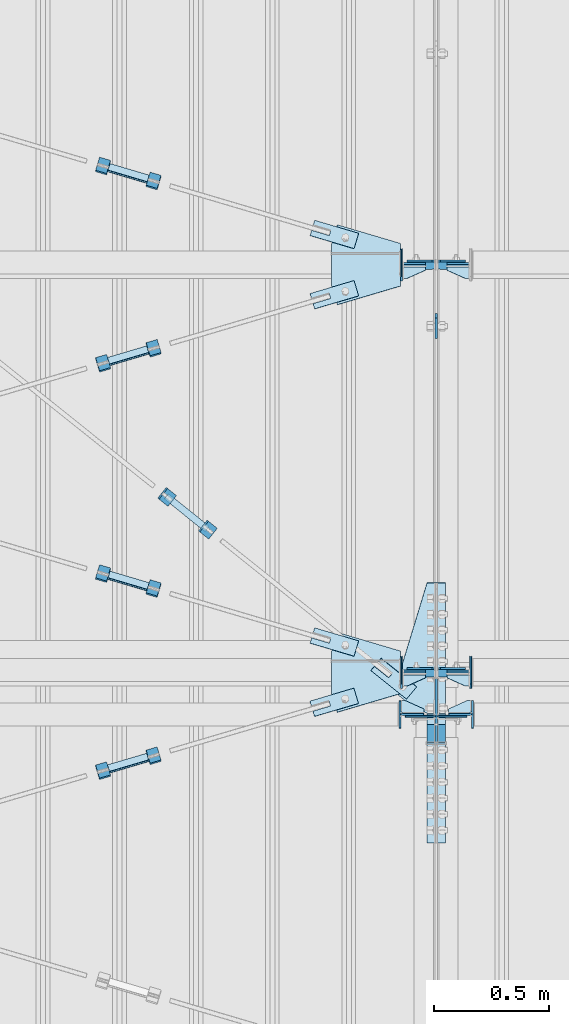
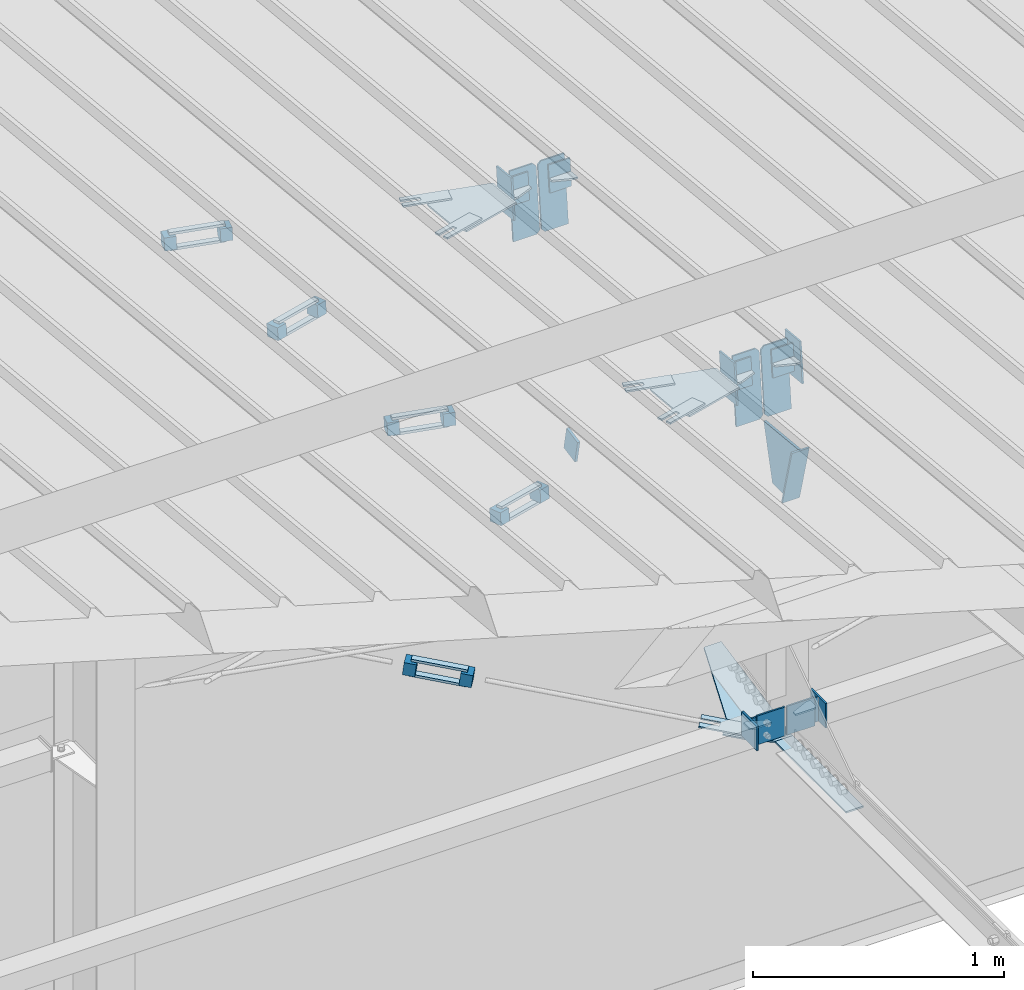
# One storey, part 134 of 709: 55 plates, 4 openings, 19 elements without a shape of their own.
"""IFC4 building model written with IfcOpenShell, lengths in millimetres."""

import ifcopenshell
import ifcopenshell.guid

model = None  # the IFC model being written
_history = None  # IfcOwnerHistory: only IFC2X3 demands one
_inside = {}  # id of a spatial element -> (the spatial element, [elements in it])
_under = {}  # id of a project, library or spatial element -> (it, [spatial elements below it])
_declared = {}  # id of a project -> (the project, [libraries it declares])
_typed = {}  # id of a type object -> (the type object, [elements of that type])
_made_of = {}  # id of a material, layer set ... -> (it, [elements and type objects made of it])


def new_model(schema):
    """Start an empty IFC model of exactly this schema.

    Asked for "IFC4X3", IfcOpenShell would pick the latest addendum, in which some entities
    have other attributes; the version numbers below select the first issue.
    IFC2X3 requires an IfcOwnerHistory on every rooted entity: one is made here for all.
    """
    global model, _history
    if schema == "IFC4X3":
        model = ifcopenshell.file(schema_version=(4, 3, 0, 0))
    else:
        model = ifcopenshell.file(schema=schema)
    _inside.clear()
    _under.clear()
    _declared.clear()
    _typed.clear()
    _made_of.clear()
    _history = None
    if model.schema == "IFC2X3":
        org = make("IfcOrganization", Name="unknown")
        user = make(
            "IfcPersonAndOrganization",
            ThePerson=make("IfcPerson", FamilyName="unknown"),
            TheOrganization=org,
        )
        app = make(
            "IfcApplication",
            ApplicationDeveloper=org,
            Version="unknown",
            ApplicationFullName="unknown",
            ApplicationIdentifier="unknown",
        )
        _history = make(
            "IfcOwnerHistory",
            OwningUser=user,
            OwningApplication=app,
            ChangeAction="ADDED",
            CreationDate=0,
        )
    return model


def make(cls, **values):
    """One entity of the class cls with the attributes given. An attribute that is None is left unset."""
    return model.create_entity(
        cls, **{name: value for name, value in values.items() if value is not None}
    )


def rooted(cls, **values):
    """An entity with a GlobalId (a new one), such as an element, a storey or a relation."""
    return make(cls, GlobalId=ifcopenshell.guid.new(), OwnerHistory=_history, **values)


def si_unit(unit_type, name, prefix=None):
    """IfcSIUnit, for example si_unit("LENGTHUNIT", "METRE", prefix="MILLI")."""
    return make("IfcSIUnit", UnitType=unit_type, Prefix=prefix, Name=name)


def assignment(units):
    """IfcUnitAssignment: the units of a project."""
    return None if units is None else make("IfcUnitAssignment", Units=units)


def point(xyz):
    """IfcCartesianPoint."""
    return None if xyz is None else make("IfcCartesianPoint", Coordinates=xyz)


def direction(xyz):
    """IfcDirection."""
    return None if xyz is None else make("IfcDirection", DirectionRatios=xyz)


def frame(location, z_axis=None, x_axis=None):
    """IfcAxis2Placement3D, a coordinate frame: its origin and axes. An axis left out is left unset."""
    return make(
        "IfcAxis2Placement3D",
        Location=point(location),
        Axis=direction(z_axis),
        RefDirection=direction(x_axis),
    )


def origin_with_axes():
    """The frame at (0, 0, 0) with the z axis (0, 0, 1) and the x axis (1, 0, 0) written out."""
    return frame((0.0, 0.0, 0.0), z_axis=(0.0, 0.0, 1.0), x_axis=(1.0, 0.0, 0.0))


def place(relative_to, where):
    """IfcLocalPlacement: puts the frame where relative to a parent placement (None: the world)."""
    return make(
        "IfcLocalPlacement", PlacementRelTo=relative_to, RelativePlacement=where
    )


def context(
    kind, dimensions, precision=None, world=None, true_north=None, identifier=None
):
    """IfcGeometricRepresentationContext, for example the 3D "Model" context."""
    return make(
        "IfcGeometricRepresentationContext",
        ContextIdentifier=identifier,
        ContextType=kind,
        CoordinateSpaceDimension=dimensions,
        Precision=precision,
        WorldCoordinateSystem=world,
        TrueNorth=true_north,
    )


def subcontext(parent, identifier, kind, view, scale=None):
    """IfcGeometricRepresentationSubContext, for example "Body" below "Model"."""
    return make(
        "IfcGeometricRepresentationSubContext",
        ContextIdentifier=identifier,
        ContextType=kind,
        ParentContext=parent,
        TargetScale=scale,
        TargetView=view,
    )


def project(units=None, contexts=None):
    """IfcProject with its units and contexts."""
    return rooted(
        "IfcProject",
        Name="project",
        RepresentationContexts=contexts,
        UnitsInContext=assignment(units),
    )


def spatial(cls, under=None, at=None, **own):
    """A site, building, storey or space (cls), placed at a placement, below another one or the project."""
    s = rooted(cls, ObjectPlacement=at, **own)
    if under is not None:
        _under.setdefault(under.id(), (under, []))[1].append(s)
    return s


def point_list(points):
    """IfcCartesianPointList2D or 3D."""
    cls = (
        "IfcCartesianPointList2D" if len(points[0]) == 2 else "IfcCartesianPointList3D"
    )
    return make(cls, CoordList=points)


def line(*indices):
    """IfcLineIndex: a straight run through numbered points of an indexed curve."""
    return model.create_entity("IfcLineIndex", indices)


def indexed_curve(points, segments=None, self_intersect=None):
    """IfcIndexedPolyCurve: lines and arcs through numbered points (the first is 1)."""
    return make(
        "IfcIndexedPolyCurve",
        Points=point_list(points),
        Segments=segments,
        SelfIntersect=self_intersect,
    )


def outline(outer, holes=None, kind="AREA"):
    """IfcArbitraryClosedProfileDef: a profile drawn as a closed curve; with holes, ...WithVoids."""
    if holes is None:
        return make("IfcArbitraryClosedProfileDef", ProfileType=kind, OuterCurve=outer)
    return make(
        "IfcArbitraryProfileDefWithVoids",
        ProfileType=kind,
        OuterCurve=outer,
        InnerCurves=holes,
    )


def extrude(swept, where, along, depth):
    """IfcExtrudedAreaSolid: the profile swept, set in the frame where, extruded along a direction by depth."""
    return make(
        "IfcExtrudedAreaSolid",
        SweptArea=swept,
        Position=where,
        ExtrudedDirection=direction(along),
        Depth=depth,
    )


def shape(context_of_items, identifier, shape_type, items):
    """IfcShapeRepresentation: the items that make up one representation, for example the "Body"."""
    return make(
        "IfcShapeRepresentation",
        ContextOfItems=context_of_items,
        RepresentationIdentifier=identifier,
        RepresentationType=shape_type,
        Items=items,
    )


def material(Name=None, Category=None):
    """IfcMaterial."""
    return make("IfcMaterial", Name=Name, Category=Category)


def made_of(thing, what):
    """Note that an element or type object is made of a material, layer set ...; save() writes the relation."""
    if what is not None:
        _made_of.setdefault(what.id(), (what, []))[1].append(thing)
    return thing


def element(
    cls,
    number,
    at=None,
    inside=None,
    cuts=None,
    type_object=None,
    material=None,
    context=None,
    identifier="Body",
    shape_type=None,
    held_by="IfcProductDefinitionShape",
    body=None,
    shapes=None,
    **own,
):
    """One element of the class cls, such as IfcWall. Its Tag is "e" and its number.

    at: its placement. inside: the storey or other place that contains it. cuts: it is an
    opening in that element (IfcRelVoidsElement). A single representation is given by context,
    identifier, shape_type and body (its items); several are given by shapes. held_by: the class
    of the entity that holds the representations. save() writes the other relations.
    """
    e = rooted(cls, Tag="e%d" % number, ObjectPlacement=at, **own)
    if body is not None:
        shapes = [shape(context, identifier, shape_type, body)]
    if shapes is not None:
        e.Representation = make(held_by, Representations=shapes)
    if inside is not None:
        _inside.setdefault(inside.id(), (inside, []))[1].append(e)
    if cuts is not None:
        rooted(
            "IfcRelVoidsElement", RelatingBuildingElement=cuts, RelatedOpeningElement=e
        )
    if type_object is not None:
        _typed.setdefault(type_object.id(), (type_object, []))[1].append(e)
    return made_of(e, material)


def aggregate(whole, parts):
    """IfcRelAggregates: a whole, such as a stair, and the parts it consists of."""
    return rooted("IfcRelAggregates", RelatingObject=whole, RelatedObjects=parts)


def save(model, path):
    """Write the relations noted so far, then the file.

    IfcRelAggregates (storeys below a building ...), IfcRelContainedInSpatialStructure (elements
    in a storey), IfcRelDefinesByType, IfcRelAssociatesMaterial and IfcRelDeclares: one each for
    every whole, place, type object, material and project.
    """
    for whole, parts in _under.values():
        aggregate(whole, parts)
    for where, things in _inside.values():
        rooted(
            "IfcRelContainedInSpatialStructure",
            RelatedElements=things,
            RelatingStructure=where,
        )
    for kind, things in _typed.values():
        rooted("IfcRelDefinesByType", RelatedObjects=things, RelatingType=kind)
    for what, things in _made_of.values():
        rooted("IfcRelAssociatesMaterial", RelatedObjects=things, RelatingMaterial=what)
    for by, libraries in _declared.values():
        rooted("IfcRelDeclares", RelatingContext=by, RelatedDefinitions=libraries)
    model.write(path)


model = new_model("IFC4")

# Units and contexts
model_context = context("Model", 3, precision=0.2, world=origin_with_axes(), true_north=direction((0.0, 1.0)))
body_context = subcontext(model_context, "Body", "Model", "MODEL_VIEW")
ifc_project = project(units=[si_unit("LENGTHUNIT", "METRE", prefix="MILLI"), si_unit("AREAUNIT", "SQUARE_METRE"), si_unit("VOLUMEUNIT", "CUBIC_METRE"), si_unit("MASSUNIT", "GRAM", prefix="KILO"), si_unit("TIMEUNIT", "SECOND"), si_unit("PLANEANGLEUNIT", "RADIAN"), si_unit("SOLIDANGLEUNIT", "STERADIAN"), si_unit("THERMODYNAMICTEMPERATUREUNIT", "DEGREE_CELSIUS"), si_unit("LUMINOUSINTENSITYUNIT", "LUMEN")], contexts=[model_context])

# Site, building, storey
site_placement = place(None, origin_with_axes())
site = spatial("IfcSite", under=ifc_project, at=site_placement, CompositionType="ELEMENT")
building_placement = place(site_placement, origin_with_axes())
building = spatial("IfcBuilding", under=site, at=building_placement, Name="Undefined", CompositionType="ELEMENT")
storey_placement = place(building_placement, origin_with_axes())
storey = spatial("IfcBuildingStorey", under=building, at=storey_placement, Name="Undefined", CompositionType="ELEMENT", Elevation=0.0)

# Assembly, plates
assembly_1_placement = place(storey_placement, frame((10000.0, 21654.0, 7089.70002), z_axis=(-1.0, 0.0, 0.0), x_axis=(0.0, -0.9950371902, 0.099503719)))
assembly_1 = element("IfcElementAssembly", 1, at=assembly_1_placement, inside=storey)
ifc_material_1 = material(Name="C355-6", Category="STEEL")
plate_1_placement = place(assembly_1_placement, frame((3383.44474, 163.0, -127.0), z_axis=(1.0, 0.0, 0.0), x_axis=(0.0, 0.0, 1.0)))
plate_1 = element("IfcPlate", 2, at=plate_1_placement, material=ifc_material_1, ObjectType="585", context=body_context, shape_type="SolidModel", body=[
    extrude(outline(indexed_curve([(0.0, 0.0), (108.0, 0.0), (123.0, 15.0), (123.0, 311.0), (108.0, 326.0), (0.0, 326.0)], segments=[line(1, 2, 3, 4, 5, 6, 1)])), frame((0.0, 0.0, 4.0), z_axis=(0.0, 0.0, 1.0), x_axis=(1.0, 0.0, 0.0)), (0.0, 0.0, -1.0), 8.0),
])
plate_2_placement = place(assembly_1_placement, frame((3383.44474, 163.0, 127.0), z_axis=(-1.0, 0.0, 0.0), x_axis=(0.0, 0.0, -1.0)))
plate_2 = element("IfcPlate", 3, at=plate_2_placement, material=ifc_material_1, ObjectType="585", context=body_context, shape_type="SolidModel", body=[
    extrude(outline(indexed_curve([(0.0, 0.0), (108.0, 0.0), (123.0, 15.0), (123.0, 311.0), (108.0, 326.0), (0.0, 326.0)], segments=[line(1, 2, 3, 4, 5, 6, 1)])), frame((0.0, 0.0, 4.0), z_axis=(0.0, 0.0, 1.0), x_axis=(1.0, 0.0, 0.0)), (0.0, 0.0, -1.0), 8.0),
])
plate_3_placement = place(assembly_1_placement, frame((5169.0059, 163.0, -127.0), z_axis=(1.0, 0.0, 0.0), x_axis=(0.0, 0.0, 1.0)))
plate_3 = element("IfcPlate", 4, at=plate_3_placement, material=ifc_material_1, ObjectType="585", context=body_context, shape_type="SolidModel", body=[
    extrude(outline(indexed_curve([(0.0, 0.0), (108.0, 0.0), (123.0, 15.0), (123.0, 311.0), (108.0, 326.0), (0.0, 326.0)], segments=[line(1, 2, 3, 4, 5, 6, 1)])), frame((0.0, 0.0, 4.0), z_axis=(0.0, 0.0, 1.0), x_axis=(1.0, 0.0, 0.0)), (0.0, 0.0, -1.0), 8.0),
])
plate_4_placement = place(assembly_1_placement, frame((5169.0059, 163.0, 127.0), z_axis=(-1.0, 0.0, 0.0), x_axis=(0.0, 0.0, -1.0)))
plate_4 = element("IfcPlate", 5, at=plate_4_placement, material=ifc_material_1, ObjectType="585", context=body_context, shape_type="SolidModel", body=[
    extrude(outline(indexed_curve([(0.0, 0.0), (108.0, 0.0), (123.0, 15.0), (123.0, 311.0), (108.0, 326.0), (0.0, 326.0)], segments=[line(1, 2, 3, 4, 5, 6, 1)])), frame((0.0, 0.0, 4.0), z_axis=(0.0, 0.0, 1.0), x_axis=(1.0, 0.0, 0.0)), (0.0, 0.0, -1.0), 8.0),
])
plate_5_placement = place(assembly_1_placement, frame((5223.64782, -437.93487, 0.0), z_axis=(0.0, 0.0, -1.0), x_axis=(-0.1614213634, 0.9868855777, 0.0)))
plate_5 = element("IfcPlate", 6, at=plate_5_placement, material=ifc_material_1, ObjectType="442", context=body_context, shape_type="SolidModel", body=[
    extrude(outline(indexed_curve([(0.0, 0.0), (270.19115, 0.0), (225.20717, 275.01958), (-33.64648, 125.57036)], segments=[line(1, 2, 3, 4, 1)])), frame((0.0, 0.0, 6.0), z_axis=(0.0, 0.0, 1.0), x_axis=(1.0, 0.0, 0.0)), (0.0, 0.0, -1.0), 12.0),
])
plate_6_placement = place(assembly_1_placement, frame((5462.44895, -172.70172, -40.0), z_axis=(-0.9353786626, 0.3536477874, 0.0), x_axis=(-0.3536477874, -0.9353786626, 0.0)))
plate_6 = element("IfcPlate", 7, at=plate_6_placement, material=ifc_material_1, ObjectType="443", context=body_context, shape_type="SolidModel", body=[
    extrude(outline(indexed_curve([(0.0, 0.0), (298.89845, 0.0), (298.89845, 80.0), (0.0, 80.0)], segments=[line(1, 2, 3, 4, 1)])), frame((0.0, 0.0, 4.0), z_axis=(0.0, 0.0, 1.0), x_axis=(1.0, 0.0, 0.0)), (0.0, 0.0, -1.0), 8.0),
])
aggregate(assembly_1, [plate_1, plate_2, plate_3, plate_4, plate_5, plate_6])

# Assembly, plate
assembly_2_placement = place(storey_placement, frame((8916.07962, 17203.7647, 6158.55487), z_axis=(-0.625451877, -0.7802627439, 1e-10), x_axis=(0.7742288439, -0.6206151549, -0.124123031)))
assembly_2 = element("IfcElementAssembly", 8, at=assembly_2_placement, inside=storey)
plate_7_placement = place(assembly_2_placement, frame((1061.42526, -5.35577, 34.5878), z_axis=(1e-10, 0.9882227648, 0.1530221135), x_axis=(1.0, 0.0, 0.0)))
plate_7 = element("IfcPlate", 9, at=plate_7_placement, material=ifc_material_1, ObjectType="488", context=body_context, shape_type="SolidModel", body=[
    extrude(outline(indexed_curve([(0.0, 0.0), (200.0, 0.0), (200.0, 70.0), (0.0, 70.0), (0.0, 46.0), (80.0, 46.0), (80.0, 24.0), (0.0, 24.0)], segments=[line(1, 2, 3, 4, 5, 6, 7, 8, 1)])), frame((0.0, 0.0, 4.0), z_axis=(0.0, 0.0, 1.0), x_axis=(1.0, 0.0, 0.0)), (0.0, 0.0, -1.0), 8.0),
])
aggregate(assembly_2, [plate_7])

# Assembly, plates
assembly_3_placement = place(storey_placement, frame((8989.25784, 17106.65708, 6174.04872), z_axis=(-0.7742288439, 0.6206151548, 0.1241230313), x_axis=(0.625451877, 0.780262744, 0.0)))
assembly_3 = element("IfcElementAssembly", 10, at=assembly_3_placement, inside=storey)
ifc_material_2 = material(Name="Steel_Undefined", Category="STEEL")
plate_8_placement = place(assembly_3_placement, origin_with_axes())
plate_8 = element("IfcPlate", 11, at=plate_8_placement, material=ifc_material_2, ObjectType="482", context=body_context, shape_type="SolidModel", body=[
    extrude(outline(indexed_curve([(0.0, 0.0), (60.0, 0.0), (60.0, 60.0), (0.0, 60.0)], segments=[line(1, 2, 3, 4, 1)])), frame((0.0, 0.0, 25.0), z_axis=(0.0, 0.0, 1.0), x_axis=(1.0, 0.0, 0.0)), (0.0, 0.0, -1.0), 50.0),
])
plate_9_placement = place(assembly_3_placement, frame((15.0, -6.0, 230.0), z_axis=(0.0, 1.0, 0.0), x_axis=(1.0, 0.0, 0.0)))
plate_9 = element("IfcPlate", 12, at=plate_9_placement, material=ifc_material_2, ObjectType="484", context=body_context, shape_type="SolidModel", body=[
    extrude(outline(indexed_curve([(0.0, 0.0), (30.0, 0.0), (30.0, 230.0), (0.0, 230.0)], segments=[line(1, 2, 3, 4, 1)])), frame((0.0, 0.0, 6.0), z_axis=(0.0, 0.0, 1.0), x_axis=(1.0, 0.0, 0.0)), (0.0, 0.0, -1.0), 12.0),
])
plate_10_placement = place(assembly_3_placement, frame((15.0, 66.0, 230.0), z_axis=(0.0, 1.0, 0.0), x_axis=(1.0, 0.0, 0.0)))
plate_10 = element("IfcPlate", 13, at=plate_10_placement, material=ifc_material_2, ObjectType="484", context=body_context, shape_type="SolidModel", body=[
    extrude(outline(indexed_curve([(0.0, 0.0), (30.0, 0.0), (30.0, 230.0), (0.0, 230.0)], segments=[line(1, 2, 3, 4, 1)])), frame((0.0, 0.0, 6.0), z_axis=(0.0, 0.0, 1.0), x_axis=(1.0, 0.0, 0.0)), (0.0, 0.0, -1.0), 12.0),
])
plate_11_placement = place(assembly_3_placement, frame((0.0, 0.0, 230.0), z_axis=(0.0, 0.0, 1.0), x_axis=(1.0, 0.0, 0.0)))
plate_11 = element("IfcPlate", 14, at=plate_11_placement, material=ifc_material_2, ObjectType="483", context=body_context, shape_type="SolidModel", body=[
    extrude(outline(indexed_curve([(0.0, 0.0), (60.0, 0.0), (60.0, 60.0), (0.0, 60.0)], segments=[line(1, 2, 3, 4, 1)])), frame((0.0, 0.0, 25.0), z_axis=(0.0, 0.0, 1.0), x_axis=(1.0, 0.0, 0.0)), (0.0, 0.0, -1.0), 50.0),
])
aggregate(assembly_3, [plate_8, plate_9, plate_10, plate_11])

assembly_4_placement = place(storey_placement, frame((10000.0, 16331.38656, 5980.00002), z_axis=(-1.0, 0.0, 0.0), x_axis=(0.0, -1.0, 0.0)))
assembly_4 = element("IfcElementAssembly", 15, at=assembly_4_placement, inside=storey)
plate_12_placement = place(assembly_4_placement, frame((12.38656, 164.3, -134.0), z_axis=(1.0, 0.0, 0.0), x_axis=(0.0, 0.0, 1.0)))
plate_12 = element("IfcPlate", 16, at=plate_12_placement, material=ifc_material_1, ObjectType="558", context=body_context, shape_type="SolidModel", body=[
    extrude(outline(indexed_curve([(0.0, 0.0), (130.0, 0.0), (130.0, 140.0), (0.0, 140.0)], segments=[line(1, 2, 3, 4, 1)])), frame((0.0, 0.0, 4.0), z_axis=(0.0, 0.0, 1.0), x_axis=(1.0, 0.0, 0.0)), (0.0, 0.0, -1.0), 8.0),
])
plate_13_placement = place(assembly_4_placement, frame((12.38656, 164.3, 134.0), z_axis=(-1.0, 0.0, 0.0), x_axis=(0.0, 0.0, -1.0)))
plate_13 = element("IfcPlate", 17, at=plate_13_placement, material=ifc_material_1, ObjectType="558", context=body_context, shape_type="SolidModel", body=[
    extrude(outline(indexed_curve([(0.0, 0.0), (130.0, 0.0), (130.0, 140.0), (0.0, 140.0)], segments=[line(1, 2, 3, 4, 1)])), frame((0.0, 0.0, 4.0), z_axis=(0.0, 0.0, 1.0), x_axis=(1.0, 0.0, 0.0)), (0.0, 0.0, -1.0), 8.0),
])
plate_14_placement = place(assembly_4_placement, frame((-0.78446, -3.92232, 40.0), z_axis=(0.1961161349, 0.9805806757, 0.0), x_axis=(0.0, 0.0, -1.0)))
plate_14 = element("IfcPlate", 18, at=plate_14_placement, material=ifc_material_1, ObjectType="487", context=body_context, shape_type="SolidModel", body=[
    extrude(outline(indexed_curve([(0.0, 0.0), (80.0, 0.0), (80.0, 579.50696), (0.0, 579.50696), (-116.23068, 190.22219), (-173.1922, 120.5416), (-95.76932, 57.25102)], segments=[line(1, 2, 3, 4, 5, 6, 7, 1)])), frame((0.0, 0.0, 4.0), z_axis=(0.0, 0.0, 1.0), x_axis=(1.0, 0.0, 0.0)), (0.0, 0.0, -1.0), 8.0),
])
plate_15_placement = place(assembly_4_placement, frame((564.38656, -4.0, -40.0), z_axis=(0.0, 1.0, 0.0), x_axis=(-1.0, 0.0, 0.0)))
plate_15 = element("IfcPlate", 19, at=plate_15_placement, material=ifc_material_1, ObjectType="446", context=body_context, shape_type="SolidModel", body=[
    extrude(outline(indexed_curve([(0.0, 0.0), (564.38656, 0.0), (564.38656, 80.0), (0.0, 80.0)], segments=[line(1, 2, 3, 4, 1)])), frame((0.0, 0.0, 4.0), z_axis=(0.0, 0.0, 1.0), x_axis=(1.0, 0.0, 0.0)), (0.0, 0.0, -1.0), 8.0),
])
aggregate(assembly_4, [plate_12, plate_13, plate_14, plate_15])

# Assembly, plate
assembly_5_placement = place(storey_placement, frame((10000.0, 18053.91701, 6446.88258), z_axis=(1.0, 0.0, 0.0), x_axis=(0.0, -0.9805806757, -0.1961161349)))
assembly_5 = element("IfcElementAssembly", 20, at=assembly_5_placement, inside=storey)
plate_16_placement = place(assembly_5_placement, origin_with_axes())
plate_16 = element("IfcPlate", 21, at=plate_16_placement, material=ifc_material_1, ObjectType="491", context=body_context, shape_type="SolidModel", body=[
    extrude(outline(indexed_curve([(0.0, 0.0), (90.0, 0.0), (90.0, 110.0), (0.0, 110.0)], segments=[line(1, 2, 3, 4, 1)])), frame((0.0, 0.0, 6.0), z_axis=(0.0, 0.0, 1.0), x_axis=(1.0, 0.0, 0.0)), (0.0, 0.0, -1.0), 12.0),
])
aggregate(assembly_5, [plate_16])

# Assembly, plates
assembly_6_placement = place(storey_placement, frame((4000.0, 16327.0, 6074.30002), z_axis=(0.0, -1.0, 0.0), x_axis=(1.0, 0.0, 0.0)))
assembly_6 = element("IfcElementAssembly", 22, at=assembly_6_placement, inside=storey)
plate_17_placement = place(assembly_6_placement, frame((5946.0, 0.0, -60.0), z_axis=(0.0, -1.0, 0.0), x_axis=(0.0, 0.0, 1.0)))
plate_17 = element("IfcPlate", 23, at=plate_17_placement, material=ifc_material_1, ObjectType="561", context=body_context, shape_type="SolidModel", body=[
    extrude(outline(indexed_curve([(0.0, 80.0), (36.0, 0.0), (56.0, 0.0), (56.0, 90.0), (46.0, 100.0), (0.0, 100.0)], segments=[line(1, 2, 3, 4, 5, 6, 1)])), frame((0.0, 0.0, 4.0), z_axis=(0.0, 0.0, 1.0), x_axis=(1.0, 0.0, 0.0)), (0.0, 0.0, -1.0), 8.0),
])
plate_18_placement = place(assembly_6_placement, frame((5842.0, -60.0, 60.0), z_axis=(1.0, 0.0, 0.0), x_axis=(0.0, 0.0, -1.0)))
plate_18 = element("IfcPlate", 24, at=plate_18_placement, material=ifc_material_1, ObjectType="559", context=body_context, shape_type="SolidModel", body=[
    extrude(outline(indexed_curve([(0.0, 0.0), (120.0, 0.0), (120.0, 120.0), (0.0, 120.0)], segments=[line(1, 2, 3, 4, 1)])), frame((0.0, 0.0, 4.0), z_axis=(0.0, 0.0, 1.0), x_axis=(1.0, 0.0, 0.0)), (0.0, 0.0, -1.0), 8.0),
])
plate_19_placement = place(assembly_6_placement, frame((5946.0, -60.0, 0.0), z_axis=(0.0, 0.0, 1.0), x_axis=(0.0, 1.0, 0.0)))
plate_19 = element("IfcPlate", 25, at=plate_19_placement, material=ifc_material_1, ObjectType="560", context=body_context, shape_type="SolidModel", body=[
    extrude(outline(indexed_curve([(0.0, 0.0), (120.0, 0.0), (120.0, 100.0), (0.0, 100.0)], segments=[line(1, 2, 3, 4, 1)])), frame((0.0, 0.0, 4.0), z_axis=(0.0, 0.0, 1.0), x_axis=(1.0, 0.0, 0.0)), (0.0, 0.0, -1.0), 8.0),
])
aggregate(assembly_6, [plate_17, plate_18, plate_19])

assembly_7_placement = place(storey_placement, frame((10000.0, 16327.0, 6074.30002), z_axis=(0.0, -1.0, 0.0), x_axis=(1.0, 0.0, 0.0)))
assembly_7 = element("IfcElementAssembly", 26, at=assembly_7_placement, inside=storey)
plate_20_placement = place(assembly_7_placement, frame((54.0, 60.0, 0.0), z_axis=(0.0, 0.0, 1.0), x_axis=(0.0, -1.0, 0.0)))
plate_20 = element("IfcPlate", 27, at=plate_20_placement, material=ifc_material_1, ObjectType="560", context=body_context, shape_type="SolidModel", body=[
    extrude(outline(indexed_curve([(0.0, 0.0), (120.0, 0.0), (120.0, 100.0), (0.0, 100.0)], segments=[line(1, 2, 3, 4, 1)])), frame((0.0, 0.0, 4.0), z_axis=(0.0, 0.0, 1.0), x_axis=(1.0, 0.0, 0.0)), (0.0, 0.0, -1.0), 8.0),
])
plate_21_placement = place(assembly_7_placement, frame((54.0, 0.0, -60.0), z_axis=(0.0, 1.0, 0.0), x_axis=(0.0, 0.0, 1.0)))
plate_21 = element("IfcPlate", 28, at=plate_21_placement, material=ifc_material_1, ObjectType="561", context=body_context, shape_type="SolidModel", body=[
    extrude(outline(indexed_curve([(0.0, 80.0), (36.0, 0.0), (56.0, 0.0), (56.0, 90.0), (46.0, 100.0), (0.0, 100.0)], segments=[line(1, 2, 3, 4, 5, 6, 1)])), frame((0.0, 0.0, 4.0), z_axis=(0.0, 0.0, 1.0), x_axis=(1.0, 0.0, 0.0)), (0.0, 0.0, -1.0), 8.0),
])
plate_22_placement = place(assembly_7_placement, frame((158.0, 60.0, 60.0), z_axis=(-1.0, 0.0, 0.0), x_axis=(0.0, 0.0, -1.0)))
plate_22 = element("IfcPlate", 29, at=plate_22_placement, material=ifc_material_1, ObjectType="559", context=body_context, shape_type="SolidModel", body=[
    extrude(outline(indexed_curve([(0.0, 0.0), (120.0, 0.0), (120.0, 120.0), (0.0, 120.0)], segments=[line(1, 2, 3, 4, 1)])), frame((0.0, 0.0, 4.0), z_axis=(0.0, 0.0, 1.0), x_axis=(1.0, 0.0, 0.0)), (0.0, 0.0, -1.0), 8.0),
])
aggregate(assembly_7, [plate_20, plate_21, plate_22])

# Assembly, plate, voiding feature
assembly_8_placement = place(storey_placement, frame((8657.949, 16114.10317, 7725.0937), z_axis=(0.2847296511, -0.9538504697, 0.095385047), x_axis=(0.9586078582, 0.2833165921, -0.028331659)))
assembly_8 = element("IfcElementAssembly", 30, at=assembly_8_placement, inside=storey)
plate_23_placement = place(assembly_8_placement, frame((1036.31721, 0.0, 35.0), z_axis=(0.0, 1.0, 0.0), x_axis=(0.0, 0.0, -1.0)))
plate_23 = element("IfcPlate", 31, at=plate_23_placement, material=ifc_material_1, ObjectType="574", context=body_context, shape_type="SolidModel", body=[
    extrude(outline(indexed_curve([(0.0, 0.0), (70.0, 0.0), (70.0, 200.0), (0.0, 200.0)], segments=[line(1, 2, 3, 4, 1)])), frame((0.0, 0.0, 4.0), z_axis=(0.0, 0.0, 1.0), x_axis=(1.0, 0.0, 0.0)), (0.0, 0.0, -1.0), 8.0),
])
voiding_feature_1_placement = place(plate_23_placement, frame((24.0, 120.0, 0.0), z_axis=(0.0, 0.0, 1.0), x_axis=(1.0, 0.0, 0.0)))
element("IfcVoidingFeature", 32, at=voiding_feature_1_placement, cuts=plate_23, Name="PLATE", PredefinedType="HOLE", context=body_context, shape_type="SolidModel", body=[
    extrude(outline(indexed_curve([(0.0, 0.0), (22.0, 0.0), (22.0, 85.0), (0.0, 85.0)], segments=[line(1, 2, 3, 4, 1)])), frame((0.0, 0.0, 6.5), z_axis=(0.0, 0.0, 1.0), x_axis=(1.0, 0.0, 0.0)), (0.0, 0.0, -1.0), 13.0),
])
aggregate(assembly_8, [plate_23])

# Assembly, plates
assembly_9_placement = place(storey_placement, frame((8776.73079, 16121.05418, 7754.54823), z_axis=(-0.9586078582, -0.2833165918, 0.0283316592), x_axis=(-0.2847296509, 0.9538504698, -0.095385047)))
assembly_9 = element("IfcElementAssembly", 33, at=assembly_9_placement, inside=storey)
plate_24_placement = place(assembly_9_placement, frame((15.0, -6.0, 230.0), z_axis=(0.0, 1.0, 0.0), x_axis=(1.0, 0.0, 0.0)))
plate_24 = element("IfcPlate", 34, at=plate_24_placement, material=ifc_material_2, ObjectType="484", context=body_context, shape_type="SolidModel", body=[
    extrude(outline(indexed_curve([(0.0, 0.0), (30.0, 0.0), (30.0, 230.0), (0.0, 230.0)], segments=[line(1, 2, 3, 4, 1)])), frame((0.0, 0.0, 6.0), z_axis=(0.0, 0.0, 1.0), x_axis=(1.0, 0.0, 0.0)), (0.0, 0.0, -1.0), 12.0),
])
plate_25_placement = place(assembly_9_placement, origin_with_axes())
plate_25 = element("IfcPlate", 35, at=plate_25_placement, material=ifc_material_2, ObjectType="482", context=body_context, shape_type="SolidModel", body=[
    extrude(outline(indexed_curve([(0.0, 0.0), (60.0, 0.0), (60.0, 60.0), (0.0, 60.0)], segments=[line(1, 2, 3, 4, 1)])), frame((0.0, 0.0, 25.0), z_axis=(0.0, 0.0, 1.0), x_axis=(1.0, 0.0, 0.0)), (0.0, 0.0, -1.0), 50.0),
])
plate_26_placement = place(assembly_9_placement, frame((15.0, 66.0, 230.0), z_axis=(0.0, 1.0, 0.0), x_axis=(1.0, 0.0, 0.0)))
plate_26 = element("IfcPlate", 36, at=plate_26_placement, material=ifc_material_2, ObjectType="484", context=body_context, shape_type="SolidModel", body=[
    extrude(outline(indexed_curve([(0.0, 0.0), (30.0, 0.0), (30.0, 230.0), (0.0, 230.0)], segments=[line(1, 2, 3, 4, 1)])), frame((0.0, 0.0, 6.0), z_axis=(0.0, 0.0, 1.0), x_axis=(1.0, 0.0, 0.0)), (0.0, 0.0, -1.0), 12.0),
])
plate_27_placement = place(assembly_9_placement, frame((0.0, 0.0, 230.0), z_axis=(0.0, 0.0, 1.0), x_axis=(1.0, 0.0, 0.0)))
plate_27 = element("IfcPlate", 37, at=plate_27_placement, material=ifc_material_2, ObjectType="483", context=body_context, shape_type="SolidModel", body=[
    extrude(outline(indexed_curve([(0.0, 0.0), (60.0, 0.0), (60.0, 60.0), (0.0, 60.0)], segments=[line(1, 2, 3, 4, 1)])), frame((0.0, 0.0, 25.0), z_axis=(0.0, 0.0, 1.0), x_axis=(1.0, 0.0, 0.0)), (0.0, 0.0, -1.0), 50.0),
])
aggregate(assembly_9, [plate_24, plate_25, plate_26, plate_27])

# Assembly, plate, voiding feature
assembly_10_placement = place(storey_placement, frame((8658.15773, 17890.10435, 7547.49358), z_axis=(0.2852311229, -0.9537021177, 0.0953702118), x_axis=(0.9584587662, 0.2838155751, -0.028381558)))
assembly_10 = element("IfcElementAssembly", 38, at=assembly_10_placement, inside=storey)
plate_28_placement = place(assembly_10_placement, frame((1036.9749, 0.0, 35.0), z_axis=(0.0, 1.0, 0.0), x_axis=(0.0, 0.0, -1.0)))
plate_28 = element("IfcPlate", 39, at=plate_28_placement, material=ifc_material_1, ObjectType="574", context=body_context, shape_type="SolidModel", body=[
    extrude(outline(indexed_curve([(0.0, 0.0), (70.0, 0.0), (70.0, 200.0), (0.0, 200.0)], segments=[line(1, 2, 3, 4, 1)])), frame((0.0, 0.0, 4.0), z_axis=(0.0, 0.0, 1.0), x_axis=(1.0, 0.0, 0.0)), (0.0, 0.0, -1.0), 8.0),
])
voiding_feature_2_placement = place(plate_28_placement, frame((24.0, 120.0, 0.0), z_axis=(0.0, 0.0, 1.0), x_axis=(1.0, 0.0, 0.0)))
element("IfcVoidingFeature", 40, at=voiding_feature_2_placement, cuts=plate_28, Name="PLATE", PredefinedType="HOLE", context=body_context, shape_type="SolidModel", body=[
    extrude(outline(indexed_curve([(0.0, 0.0), (22.0, 0.0), (22.0, 85.0), (0.0, 85.0)], segments=[line(1, 2, 3, 4, 1)])), frame((0.0, 0.0, 6.5), z_axis=(0.0, 0.0, 1.0), x_axis=(1.0, 0.0, 0.0)), (0.0, 0.0, -1.0), 13.0),
])
aggregate(assembly_10, [plate_28])

# Assembly, plates
assembly_11_placement = place(storey_placement, frame((8776.93742, 17897.11719, 7576.94192), z_axis=(-0.9584587662, -0.2838155751, 0.0283815575), x_axis=(-0.2852311229, 0.9537021176, -0.095370212)))
assembly_11 = element("IfcElementAssembly", 41, at=assembly_11_placement, inside=storey)
plate_29_placement = place(assembly_11_placement, origin_with_axes())
plate_29 = element("IfcPlate", 42, at=plate_29_placement, material=ifc_material_2, ObjectType="482", context=body_context, shape_type="SolidModel", body=[
    extrude(outline(indexed_curve([(0.0, 0.0), (60.0, 0.0), (60.0, 60.0), (0.0, 60.0)], segments=[line(1, 2, 3, 4, 1)])), frame((0.0, 0.0, 25.0), z_axis=(0.0, 0.0, 1.0), x_axis=(1.0, 0.0, 0.0)), (0.0, 0.0, -1.0), 50.0),
])
plate_30_placement = place(assembly_11_placement, frame((15.0, 66.0, 230.0), z_axis=(0.0, 1.0, 0.0), x_axis=(1.0, 0.0, 0.0)))
plate_30 = element("IfcPlate", 43, at=plate_30_placement, material=ifc_material_2, ObjectType="484", context=body_context, shape_type="SolidModel", body=[
    extrude(outline(indexed_curve([(0.0, 0.0), (30.0, 0.0), (30.0, 230.0), (0.0, 230.0)], segments=[line(1, 2, 3, 4, 1)])), frame((0.0, 0.0, 6.0), z_axis=(0.0, 0.0, 1.0), x_axis=(1.0, 0.0, 0.0)), (0.0, 0.0, -1.0), 12.0),
])
plate_31_placement = place(assembly_11_placement, frame((0.0, 0.0, 230.0), z_axis=(0.0, 0.0, 1.0), x_axis=(1.0, 0.0, 0.0)))
plate_31 = element("IfcPlate", 44, at=plate_31_placement, material=ifc_material_2, ObjectType="483", context=body_context, shape_type="SolidModel", body=[
    extrude(outline(indexed_curve([(0.0, 0.0), (60.0, 0.0), (60.0, 60.0), (0.0, 60.0)], segments=[line(1, 2, 3, 4, 1)])), frame((0.0, 0.0, 25.0), z_axis=(0.0, 0.0, 1.0), x_axis=(1.0, 0.0, 0.0)), (0.0, 0.0, -1.0), 50.0),
])
plate_32_placement = place(assembly_11_placement, frame((15.0, -6.0, 230.0), z_axis=(0.0, 1.0, 0.0), x_axis=(1.0, 0.0, 0.0)))
plate_32 = element("IfcPlate", 45, at=plate_32_placement, material=ifc_material_2, ObjectType="484", context=body_context, shape_type="SolidModel", body=[
    extrude(outline(indexed_curve([(0.0, 0.0), (30.0, 0.0), (30.0, 230.0), (0.0, 230.0)], segments=[line(1, 2, 3, 4, 1)])), frame((0.0, 0.0, 6.0), z_axis=(0.0, 0.0, 1.0), x_axis=(1.0, 0.0, 0.0)), (0.0, 0.0, -1.0), 12.0),
])
aggregate(assembly_11, [plate_29, plate_30, plate_31, plate_32])

# Assembly, plate, voiding feature
assembly_12_placement = place(storey_placement, frame((8658.15773, 16908.08821, 7645.6952), z_axis=(-0.2852311229, -0.9537021177, 0.0953702118), x_axis=(0.9584587662, -0.2838155751, 0.028381558)))
assembly_12 = element("IfcElementAssembly", 46, at=assembly_12_placement, inside=storey)
plate_33_placement = place(assembly_12_placement, frame((1036.9749, 0.0, 35.0), z_axis=(0.0, 1.0, 0.0), x_axis=(0.0, 0.0, -1.0)))
plate_33 = element("IfcPlate", 47, at=plate_33_placement, material=ifc_material_1, ObjectType="574", context=body_context, shape_type="SolidModel", body=[
    extrude(outline(indexed_curve([(0.0, 0.0), (70.0, 0.0), (70.0, 200.0), (0.0, 200.0)], segments=[line(1, 2, 3, 4, 1)])), frame((0.0, 0.0, 4.0), z_axis=(0.0, 0.0, 1.0), x_axis=(1.0, 0.0, 0.0)), (0.0, 0.0, -1.0), 8.0),
])
voiding_feature_3_placement = place(plate_33_placement, frame((24.0, 120.0, 0.0), z_axis=(0.0, 0.0, 1.0), x_axis=(1.0, 0.0, 0.0)))
element("IfcVoidingFeature", 48, at=voiding_feature_3_placement, cuts=plate_33, Name="PLATE", PredefinedType="HOLE", context=body_context, shape_type="SolidModel", body=[
    extrude(outline(indexed_curve([(0.0, 0.0), (22.0, 0.0), (22.0, 85.0), (0.0, 85.0)], segments=[line(1, 2, 3, 4, 1)])), frame((0.0, 0.0, 6.5), z_axis=(0.0, 0.0, 1.0), x_axis=(1.0, 0.0, 0.0)), (0.0, 0.0, -1.0), 13.0),
])
aggregate(assembly_12, [plate_33])

# Assembly, plates
assembly_13_placement = place(storey_placement, frame((8759.82355, 16849.82346, 7681.6713), z_axis=(-0.9584587662, 0.2838155751, -0.0283815575), x_axis=(0.2852311229, 0.9537021176, -0.095370212)))
assembly_13 = element("IfcElementAssembly", 49, at=assembly_13_placement, inside=storey)
plate_34_placement = place(assembly_13_placement, frame((15.0, 66.0, 230.0), z_axis=(0.0, 1.0, 0.0), x_axis=(1.0, 0.0, 0.0)))
plate_34 = element("IfcPlate", 50, at=plate_34_placement, material=ifc_material_2, ObjectType="484", context=body_context, shape_type="SolidModel", body=[
    extrude(outline(indexed_curve([(0.0, 0.0), (30.0, 0.0), (30.0, 230.0), (0.0, 230.0)], segments=[line(1, 2, 3, 4, 1)])), frame((0.0, 0.0, 6.0), z_axis=(0.0, 0.0, 1.0), x_axis=(1.0, 0.0, 0.0)), (0.0, 0.0, -1.0), 12.0),
])
plate_35_placement = place(assembly_13_placement, origin_with_axes())
plate_35 = element("IfcPlate", 51, at=plate_35_placement, material=ifc_material_2, ObjectType="482", context=body_context, shape_type="SolidModel", body=[
    extrude(outline(indexed_curve([(0.0, 0.0), (60.0, 0.0), (60.0, 60.0), (0.0, 60.0)], segments=[line(1, 2, 3, 4, 1)])), frame((0.0, 0.0, 25.0), z_axis=(0.0, 0.0, 1.0), x_axis=(1.0, 0.0, 0.0)), (0.0, 0.0, -1.0), 50.0),
])
plate_36_placement = place(assembly_13_placement, frame((15.0, -6.0, 230.0), z_axis=(0.0, 1.0, 0.0), x_axis=(1.0, 0.0, 0.0)))
plate_36 = element("IfcPlate", 52, at=plate_36_placement, material=ifc_material_2, ObjectType="484", context=body_context, shape_type="SolidModel", body=[
    extrude(outline(indexed_curve([(0.0, 0.0), (30.0, 0.0), (30.0, 230.0), (0.0, 230.0)], segments=[line(1, 2, 3, 4, 1)])), frame((0.0, 0.0, 6.0), z_axis=(0.0, 0.0, 1.0), x_axis=(1.0, 0.0, 0.0)), (0.0, 0.0, -1.0), 12.0),
])
plate_37_placement = place(assembly_13_placement, frame((0.0, 0.0, 230.0), z_axis=(0.0, 0.0, 1.0), x_axis=(1.0, 0.0, 0.0)))
plate_37 = element("IfcPlate", 53, at=plate_37_placement, material=ifc_material_2, ObjectType="483", context=body_context, shape_type="SolidModel", body=[
    extrude(outline(indexed_curve([(0.0, 0.0), (60.0, 0.0), (60.0, 60.0), (0.0, 60.0)], segments=[line(1, 2, 3, 4, 1)])), frame((0.0, 0.0, 25.0), z_axis=(0.0, 0.0, 1.0), x_axis=(1.0, 0.0, 0.0)), (0.0, 0.0, -1.0), 50.0),
])
aggregate(assembly_13, [plate_34, plate_35, plate_36, plate_37])

# Assembly, plate, voiding feature
assembly_14_placement = place(storey_placement, frame((8658.15773, 18684.78796, 7468.02522), z_axis=(-0.2852311229, -0.9537021177, 0.0953702118), x_axis=(0.9584587662, -0.2838155751, 0.028381558)))
assembly_14 = element("IfcElementAssembly", 54, at=assembly_14_placement, inside=storey)
plate_38_placement = place(assembly_14_placement, frame((1036.9749, 0.0, 35.0), z_axis=(0.0, 1.0, 0.0), x_axis=(0.0, 0.0, -1.0)))
plate_38 = element("IfcPlate", 55, at=plate_38_placement, material=ifc_material_1, ObjectType="574", context=body_context, shape_type="SolidModel", body=[
    extrude(outline(indexed_curve([(0.0, 0.0), (70.0, 0.0), (70.0, 200.0), (0.0, 200.0)], segments=[line(1, 2, 3, 4, 1)])), frame((0.0, 0.0, 4.0), z_axis=(0.0, 0.0, 1.0), x_axis=(1.0, 0.0, 0.0)), (0.0, 0.0, -1.0), 8.0),
])
voiding_feature_4_placement = place(plate_38_placement, frame((24.0, 120.0, 0.0), z_axis=(0.0, 0.0, 1.0), x_axis=(1.0, 0.0, 0.0)))
element("IfcVoidingFeature", 56, at=voiding_feature_4_placement, cuts=plate_38, Name="PLATE", PredefinedType="HOLE", context=body_context, shape_type="SolidModel", body=[
    extrude(outline(indexed_curve([(0.0, 0.0), (22.0, 0.0), (22.0, 85.0), (0.0, 85.0)], segments=[line(1, 2, 3, 4, 1)])), frame((0.0, 0.0, 6.5), z_axis=(0.0, 0.0, 1.0), x_axis=(1.0, 0.0, 0.0)), (0.0, 0.0, -1.0), 13.0),
])
aggregate(assembly_14, [plate_38])

# Assembly, plates
assembly_15_placement = place(storey_placement, frame((8759.82355, 18626.52322, 7504.00132), z_axis=(-0.9584587662, 0.2838155751, -0.0283815575), x_axis=(0.2852311229, 0.9537021176, -0.095370212)))
assembly_15 = element("IfcElementAssembly", 57, at=assembly_15_placement, inside=storey)
plate_39_placement = place(assembly_15_placement, frame((15.0, -6.0, 230.0), z_axis=(0.0, 1.0, 0.0), x_axis=(1.0, 0.0, 0.0)))
plate_39 = element("IfcPlate", 58, at=plate_39_placement, material=ifc_material_2, ObjectType="484", context=body_context, shape_type="SolidModel", body=[
    extrude(outline(indexed_curve([(0.0, 0.0), (30.0, 0.0), (30.0, 230.0), (0.0, 230.0)], segments=[line(1, 2, 3, 4, 1)])), frame((0.0, 0.0, 6.0), z_axis=(0.0, 0.0, 1.0), x_axis=(1.0, 0.0, 0.0)), (0.0, 0.0, -1.0), 12.0),
])
plate_40_placement = place(assembly_15_placement, origin_with_axes())
plate_40 = element("IfcPlate", 59, at=plate_40_placement, material=ifc_material_2, ObjectType="482", context=body_context, shape_type="SolidModel", body=[
    extrude(outline(indexed_curve([(0.0, 0.0), (60.0, 0.0), (60.0, 60.0), (0.0, 60.0)], segments=[line(1, 2, 3, 4, 1)])), frame((0.0, 0.0, 25.0), z_axis=(0.0, 0.0, 1.0), x_axis=(1.0, 0.0, 0.0)), (0.0, 0.0, -1.0), 50.0),
])
plate_41_placement = place(assembly_15_placement, frame((0.0, 0.0, 230.0), z_axis=(0.0, 0.0, 1.0), x_axis=(1.0, 0.0, 0.0)))
plate_41 = element("IfcPlate", 60, at=plate_41_placement, material=ifc_material_2, ObjectType="483", context=body_context, shape_type="SolidModel", body=[
    extrude(outline(indexed_curve([(0.0, 0.0), (60.0, 0.0), (60.0, 60.0), (0.0, 60.0)], segments=[line(1, 2, 3, 4, 1)])), frame((0.0, 0.0, 25.0), z_axis=(0.0, 0.0, 1.0), x_axis=(1.0, 0.0, 0.0)), (0.0, 0.0, -1.0), 50.0),
])
plate_42_placement = place(assembly_15_placement, frame((15.0, 66.0, 230.0), z_axis=(0.0, 1.0, 0.0), x_axis=(1.0, 0.0, 0.0)))
plate_42 = element("IfcPlate", 61, at=plate_42_placement, material=ifc_material_2, ObjectType="484", context=body_context, shape_type="SolidModel", body=[
    extrude(outline(indexed_curve([(0.0, 0.0), (30.0, 0.0), (30.0, 230.0), (0.0, 230.0)], segments=[line(1, 2, 3, 4, 1)])), frame((0.0, 0.0, 6.0), z_axis=(0.0, 0.0, 1.0), x_axis=(1.0, 0.0, 0.0)), (0.0, 0.0, -1.0), 12.0),
])
aggregate(assembly_15, [plate_39, plate_40, plate_41, plate_42])

assembly_16_placement = place(storey_placement, frame((10000.0, 16509.95037, 7677.46908), z_axis=(0.0, -0.9950371902, 0.099503719), x_axis=(-1.0, 0.0, 0.0)))
assembly_16 = element("IfcElementAssembly", 62, at=assembly_16_placement, inside=storey)
plate_43_placement = place(assembly_16_placement, frame((47.0, -65.0, 0.0), z_axis=(0.0, 0.0, 1.0), x_axis=(1.0, 0.0, 0.0)))
plate_43 = element("IfcPlate", 63, at=plate_43_placement, material=ifc_material_1, ObjectType="587", context=body_context, shape_type="SolidModel", body=[
    extrude(outline(indexed_curve([(0.0, 0.0), (100.0, 0.0), (100.0, 130.0), (0.0, 130.0)], segments=[line(1, 2, 3, 4, 1)])), frame((0.0, 0.0, 4.0), z_axis=(0.0, 0.0, 1.0), x_axis=(1.0, 0.0, 0.0)), (0.0, 0.0, -1.0), 8.0),
])
plate_44_placement = place(assembly_16_placement, frame((47.0, 0.0, 60.0), z_axis=(0.0, 1.0, 0.0), x_axis=(1.0, 0.0, 0.0)))
plate_44 = element("IfcPlate", 64, at=plate_44_placement, material=ifc_material_1, ObjectType="588", context=body_context, shape_type="SolidModel", body=[
    extrude(outline(indexed_curve([(0.0, 36.0), (80.0, 0.0), (100.0, 0.0), (100.0, 56.0), (0.0, 56.0)], segments=[line(1, 2, 3, 4, 5, 1)])), frame((0.0, 0.0, 4.0), z_axis=(0.0, 0.0, 1.0), x_axis=(1.0, 0.0, 0.0)), (0.0, 0.0, -1.0), 8.0),
])
plate_45_placement = place(assembly_16_placement, frame((151.0, -98.0, -60.0), z_axis=(-1.0, 0.0, 0.0), x_axis=(0.0, 0.0, 1.0)))
plate_45 = element("IfcPlate", 65, at=plate_45_placement, material=ifc_material_1, ObjectType="586", context=body_context, shape_type="SolidModel", body=[
    extrude(outline(indexed_curve([(0.0, 0.0), (120.0, 0.0), (120.0, 196.0), (0.0, 196.0)], segments=[line(1, 2, 3, 4, 1)])), frame((0.0, 0.0, 4.0), z_axis=(0.0, 0.0, 1.0), x_axis=(1.0, 0.0, 0.0)), (0.0, 0.0, -1.0), 8.0),
])
plate_46_placement = place(assembly_16_placement, frame((154.99945, 0.0, 92.98165), z_axis=(0.0, -1.0, 0.0), x_axis=(0.0, 0.0, -1.0)))
plate_46 = element("IfcPlate", 66, at=plate_46_placement, material=ifc_material_1, ObjectType="576", context=body_context, shape_type="SolidModel", body=[
    extrude(outline(indexed_curve([(0.0, 0.0), (186.05886, 0.0), (268.18146, 275.95562), (181.92017, 301.62642), (4.09476, 302.30336), (-82.17995, 276.67769)], segments=[line(1, 2, 3, 4, 5, 6, 1)])), frame((0.0, 0.0, 4.0), z_axis=(0.0, 0.0, 1.0), x_axis=(1.0, 0.0, 0.0)), (0.0, 0.0, -1.0), 8.0),
])
aggregate(assembly_16, [plate_43, plate_44, plate_45, plate_46])

assembly_17_placement = place(storey_placement, frame((10000.0, 18286.65012, 7499.7991), z_axis=(0.0, -0.9950371902, 0.099503719), x_axis=(-1.0, 0.0, 0.0)))
assembly_17 = element("IfcElementAssembly", 67, at=assembly_17_placement, inside=storey)
plate_47_placement = place(assembly_17_placement, frame((47.0, 0.0, 60.0), z_axis=(0.0, 1.0, 0.0), x_axis=(1.0, 0.0, 0.0)))
plate_47 = element("IfcPlate", 68, at=plate_47_placement, material=ifc_material_1, ObjectType="588", context=body_context, shape_type="SolidModel", body=[
    extrude(outline(indexed_curve([(0.0, 36.0), (80.0, 0.0), (100.0, 0.0), (100.0, 56.0), (0.0, 56.0)], segments=[line(1, 2, 3, 4, 5, 1)])), frame((0.0, 0.0, 4.0), z_axis=(0.0, 0.0, 1.0), x_axis=(1.0, 0.0, 0.0)), (0.0, 0.0, -1.0), 8.0),
])
plate_48_placement = place(assembly_17_placement, frame((47.0, -65.0, 0.0), z_axis=(0.0, 0.0, 1.0), x_axis=(1.0, 0.0, 0.0)))
plate_48 = element("IfcPlate", 69, at=plate_48_placement, material=ifc_material_1, ObjectType="587", context=body_context, shape_type="SolidModel", body=[
    extrude(outline(indexed_curve([(0.0, 0.0), (100.0, 0.0), (100.0, 130.0), (0.0, 130.0)], segments=[line(1, 2, 3, 4, 1)])), frame((0.0, 0.0, 4.0), z_axis=(0.0, 0.0, 1.0), x_axis=(1.0, 0.0, 0.0)), (0.0, 0.0, -1.0), 8.0),
])
plate_49_placement = place(assembly_17_placement, frame((151.0, -98.0, -60.0), z_axis=(-1.0, 0.0, 0.0), x_axis=(0.0, 0.0, 1.0)))
plate_49 = element("IfcPlate", 70, at=plate_49_placement, material=ifc_material_1, ObjectType="586", context=body_context, shape_type="SolidModel", body=[
    extrude(outline(indexed_curve([(0.0, 0.0), (120.0, 0.0), (120.0, 196.0), (0.0, 196.0)], segments=[line(1, 2, 3, 4, 1)])), frame((0.0, 0.0, 4.0), z_axis=(0.0, 0.0, 1.0), x_axis=(1.0, 0.0, 0.0)), (0.0, 0.0, -1.0), 8.0),
])
plate_50_placement = place(assembly_17_placement, frame((154.99945, 0.0, 93.07721), z_axis=(0.0, -1.0, 0.0), x_axis=(0.0, 0.0, -1.0)))
plate_50 = element("IfcPlate", 71, at=plate_50_placement, material=ifc_material_1, ObjectType="576", context=body_context, shape_type="SolidModel", body=[
    extrude(outline(indexed_curve([(0.0, 0.0), (186.15442, 0.0), (268.27702, 275.95562), (182.01573, 301.62642), (4.13868, 301.62642), (-82.1226, 275.95562)], segments=[line(1, 2, 3, 4, 5, 6, 1)])), frame((0.0, 0.0, 4.0), z_axis=(0.0, 0.0, 1.0), x_axis=(1.0, 0.0, 0.0)), (0.0, 0.0, -1.0), 8.0),
])
aggregate(assembly_17, [plate_47, plate_48, plate_49, plate_50])

assembly_18_placement = place(storey_placement, frame((16000.0, 16509.95037, 7677.46908), z_axis=(0.0, -0.9950371902, 0.099503719), x_axis=(-1.0, 0.0, 0.0)))
assembly_18 = element("IfcElementAssembly", 72, at=assembly_18_placement, inside=storey)
plate_51_placement = place(assembly_18_placement, frame((5953.0, 0.0, 60.0), z_axis=(0.0, -1.0, 0.0), x_axis=(-1.0, 0.0, 0.0)))
plate_51 = element("IfcPlate", 73, at=plate_51_placement, material=ifc_material_1, ObjectType="588", context=body_context, shape_type="SolidModel", body=[
    extrude(outline(indexed_curve([(0.0, 36.0), (80.0, 0.0), (100.0, 0.0), (100.0, 56.0), (0.0, 56.0)], segments=[line(1, 2, 3, 4, 5, 1)])), frame((0.0, 0.0, 4.0), z_axis=(0.0, 0.0, 1.0), x_axis=(1.0, 0.0, 0.0)), (0.0, 0.0, -1.0), 8.0),
])
plate_52_placement = place(assembly_18_placement, frame((5953.0, 65.0, 0.0), z_axis=(0.0, 0.0, 1.0), x_axis=(-1.0, 0.0, 0.0)))
plate_52 = element("IfcPlate", 74, at=plate_52_placement, material=ifc_material_1, ObjectType="587", context=body_context, shape_type="SolidModel", body=[
    extrude(outline(indexed_curve([(0.0, 0.0), (100.0, 0.0), (100.0, 130.0), (0.0, 130.0)], segments=[line(1, 2, 3, 4, 1)])), frame((0.0, 0.0, 4.0), z_axis=(0.0, 0.0, 1.0), x_axis=(1.0, 0.0, 0.0)), (0.0, 0.0, -1.0), 8.0),
])
plate_53_placement = place(assembly_18_placement, frame((5849.0, -98.0, 60.0), z_axis=(1.0, 0.0, 0.0), x_axis=(0.0, 0.0, -1.0)))
plate_53 = element("IfcPlate", 75, at=plate_53_placement, material=ifc_material_1, ObjectType="586", context=body_context, shape_type="SolidModel", body=[
    extrude(outline(indexed_curve([(0.0, 0.0), (120.0, 0.0), (120.0, 196.0), (0.0, 196.0)], segments=[line(1, 2, 3, 4, 1)])), frame((0.0, 0.0, 4.0), z_axis=(0.0, 0.0, 1.0), x_axis=(1.0, 0.0, 0.0)), (0.0, 0.0, -1.0), 8.0),
])
aggregate(assembly_18, [plate_51, plate_52, plate_53])

assembly_19_placement = place(storey_placement, frame((16000.0, 18286.65012, 7499.7991), z_axis=(0.0, -0.9950371902, 0.099503719), x_axis=(-1.0, 0.0, 0.0)))
assembly_19 = element("IfcElementAssembly", 76, at=assembly_19_placement, inside=storey)
plate_54_placement = place(assembly_19_placement, frame((5953.0, 0.0, 60.0), z_axis=(0.0, -1.0, 0.0), x_axis=(-1.0, 0.0, 0.0)))
plate_54 = element("IfcPlate", 77, at=plate_54_placement, material=ifc_material_1, ObjectType="588", context=body_context, shape_type="SolidModel", body=[
    extrude(outline(indexed_curve([(0.0, 36.0), (80.0, 0.0), (100.0, 0.0), (100.0, 56.0), (0.0, 56.0)], segments=[line(1, 2, 3, 4, 5, 1)])), frame((0.0, 0.0, 4.0), z_axis=(0.0, 0.0, 1.0), x_axis=(1.0, 0.0, 0.0)), (0.0, 0.0, -1.0), 8.0),
])
plate_55_placement = place(assembly_19_placement, frame((5953.0, 65.0, 0.0), z_axis=(0.0, 0.0, 1.0), x_axis=(-1.0, 0.0, 0.0)))
plate_55 = element("IfcPlate", 78, at=plate_55_placement, material=ifc_material_1, ObjectType="587", context=body_context, shape_type="SolidModel", body=[
    extrude(outline(indexed_curve([(0.0, 0.0), (100.0, 0.0), (100.0, 130.0), (0.0, 130.0)], segments=[line(1, 2, 3, 4, 1)])), frame((0.0, 0.0, 4.0), z_axis=(0.0, 0.0, 1.0), x_axis=(1.0, 0.0, 0.0)), (0.0, 0.0, -1.0), 8.0),
])
aggregate(assembly_19, [plate_54, plate_55])

save(model, "model.ifc")
